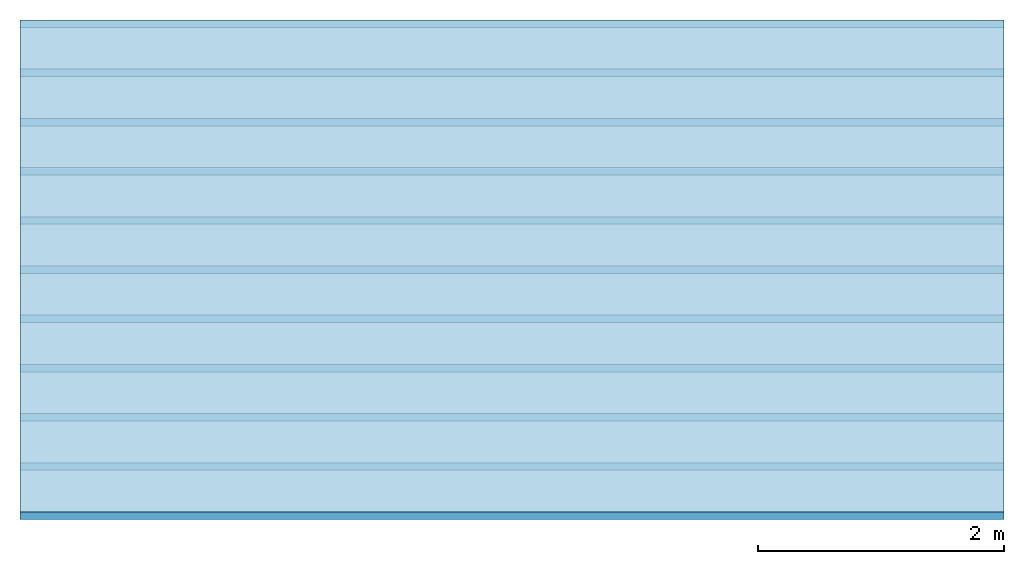
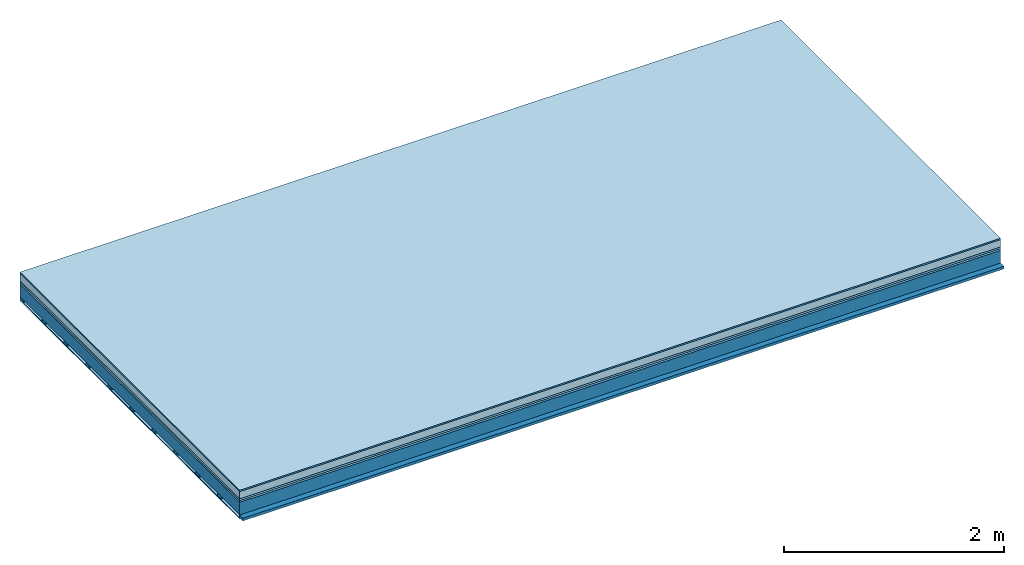
# One storey: 6 plates, 2 members, 1 element without a shape of its own.
"""IFC4 building model written with IfcOpenShell, lengths in metres."""

from ifc_helpers import new_model, si_unit, derived_unit, direction, frame, frame_2d, origin, origin_with_axes, place, context, project, spatial, rectangle, extrude, material, layer, layer_set, type_object, element, aggregate, save


model = new_model("IFC4")

# Units and contexts
plan_context = context("Plan", 3, precision=1e-05, world=origin(), true_north=direction((0.0, 1.0)))
model_context = context("Model", 3, precision=1e-05, world=origin(), true_north=direction((0.0, 1.0)))
ifc_project = project(units=[si_unit("LENGTHUNIT", "METRE"), derived_unit("SOUNDPRESSUREUNIT", [(si_unit("PRESSUREUNIT", "PASCAL", prefix="MICRO"), 0)]), si_unit("ENERGYUNIT", "JOULE", prefix="MEGA"), si_unit("MASSUNIT", "GRAM", prefix="KILO"), derived_unit("THERMALTRANSMITTANCEUNIT", [(si_unit("POWERUNIT", "WATT"), 1), (si_unit("AREAUNIT", "SQUARE_METRE"), -1), (si_unit("THERMODYNAMICTEMPERATUREUNIT", "KELVIN"), -1)]), derived_unit("AREADENSITYUNIT", [(si_unit("MASSUNIT", "GRAM", prefix="KILO"), 1), (si_unit("AREAUNIT", "SQUARE_METRE"), -1)]), derived_unit("USERDEFINED", [(si_unit("ENERGYUNIT", "JOULE", prefix="MEGA"), 1), (si_unit("AREAUNIT", "SQUARE_METRE"), -1)])], contexts=[plan_context, model_context])

# Site, building, storey
site = spatial("IfcSite", under=ifc_project)
building_placement = place(None, origin())
building = spatial("IfcBuilding", under=site, at=building_placement)
storey_placement = place(building_placement, origin())
storey = spatial("IfcBuildingStorey", under=building, at=storey_placement)

# Slab, members, plates
ifc_material_1 = material(Category="11.013")
ifc_layer_1 = layer(ifc_material_1, 0.015, Name="Flooring")
ifc_material_2 = material(Name="Cement screed", Category="04.006")
ifc_layer_2 = layer(ifc_material_2, 0.08, Name="On-material")
ifc_material_3 = material(Name="Wood fiber generic product", Category="10.009")
ifc_layer_3 = layer(ifc_material_3, 0.02, Name="Impact sound insulation")
ifc_material_4 = material(Category="10.004")
ifc_layer_4 = layer(ifc_material_4, 0.02, Name="Additional insulation")
ifc_material_5 = material(Name="no composite action")
ifc_layer_5 = layer(ifc_material_5, 0.0, Name="Bond")
ifc_layer_6 = layer(None, 0.14, Name="Supporting structure")
ifc_material_6 = material(Name="of the art")
ifc_layer_7 = layer(ifc_material_6, 0.0, Name="Bond")
ifc_layer_8 = layer(None, 0.03, Name="Battens / profiles")
ifc_material_7 = material(Name="Plasterboard type A", Category="03.008")
ifc_layer_9 = layer(ifc_material_7, 0.0125, Name="Ceiling covering 1st layer")
ifc_material_8 = material(Category="04.001")
ifc_layer_10 = layer(ifc_material_8, 0.003, Name="Surface / treatment")
ifc_layer_set = layer_set([ifc_layer_1, ifc_layer_2, ifc_layer_3, ifc_layer_4, ifc_layer_5, ifc_layer_6, ifc_layer_7, ifc_layer_8, ifc_layer_9, ifc_layer_10])
slab_type = type_object("IfcSlabType", Name="A2142", PredefinedType="NOTDEFINED", material=ifc_layer_set)
slab_placement = place(None, frame((0.0, 0.0, 0.0), z_axis=(0.0, 0.0, -1.0), x_axis=(1.0, 0.0, 0.0)))
slab = element("IfcSlab", 1, at=slab_placement, inside=storey, type_object=slab_type, material=ifc_layer_set, Name="Slab #1")
ifc_material_9 = material(Name="Solid timber panel")
member_1_placement = place(slab_placement, origin())
member_1 = element("IfcMember", 2, at=member_1_placement, material=ifc_material_9, Name="Supporting structure", context=plan_context, shape_type="SweptSolid", body=[
    extrude(rectangle(XDim=1.0, YDim=0.14, at=frame_2d((0.5, 0.07), x_axis=(1.0, 0.0))), frame((0.0, 4.0, 0.135), z_axis=(0.0, -1.0, 0.0), x_axis=(1.0, 0.0, 0.0)), (0.0, 0.0, 1.0), 4.0),
    extrude(rectangle(XDim=1.0, YDim=0.14, at=frame_2d((0.5, 0.07), x_axis=(1.0, 0.0))), frame((1.0, 4.0, 0.135), z_axis=(0.0, -1.0, 0.0), x_axis=(1.0, 0.0, 0.0)), (0.0, 0.0, 1.0), 4.0),
    extrude(rectangle(XDim=1.0, YDim=0.14, at=frame_2d((0.5, 0.07), x_axis=(1.0, 0.0))), frame((2.0, 4.0, 0.135), z_axis=(0.0, -1.0, 0.0), x_axis=(1.0, 0.0, 0.0)), (0.0, 0.0, 1.0), 4.0),
    extrude(rectangle(XDim=1.0, YDim=0.14, at=frame_2d((0.5, 0.07), x_axis=(1.0, 0.0))), frame((3.0, 4.0, 0.135), z_axis=(0.0, -1.0, 0.0), x_axis=(1.0, 0.0, 0.0)), (0.0, 0.0, 1.0), 4.0),
    extrude(rectangle(XDim=1.0, YDim=0.14, at=frame_2d((0.5, 0.07), x_axis=(1.0, 0.0))), frame((4.0, 4.0, 0.135), z_axis=(0.0, -1.0, 0.0), x_axis=(1.0, 0.0, 0.0)), (0.0, 0.0, 1.0), 4.0),
    extrude(rectangle(XDim=1.0, YDim=0.14, at=frame_2d((0.5, 0.07), x_axis=(1.0, 0.0))), frame((5.0, 4.0, 0.135), z_axis=(0.0, -1.0, 0.0), x_axis=(1.0, 0.0, 0.0)), (0.0, 0.0, 1.0), 4.0),
    extrude(rectangle(XDim=1.0, YDim=0.14, at=frame_2d((0.5, 0.07), x_axis=(1.0, 0.0))), frame((6.0, 4.0, 0.135), z_axis=(0.0, -1.0, 0.0), x_axis=(1.0, 0.0, 0.0)), (0.0, 0.0, 1.0), 4.0),
    extrude(rectangle(XDim=1.0, YDim=0.14, at=frame_2d((0.5, 0.07), x_axis=(1.0, 0.0))), frame((7.0, 4.0, 0.135), z_axis=(0.0, -1.0, 0.0), x_axis=(1.0, 0.0, 0.0)), (0.0, 0.0, 1.0), 4.0),
])
ifc_material_10 = material()
member_2_placement = place(slab_placement, origin())
member_2 = element("IfcMember", 3, at=member_2_placement, material=ifc_material_10, Name="Battens / profiles", context=plan_context, shape_type="SweptSolid", body=[
    extrude(rectangle(XDim=0.06, YDim=0.03, at=frame_2d((0.03, 0.015), x_axis=(1.0, 0.0))), frame((0.0, 0.0, 0.275), z_axis=(1.0, 0.0, 0.0), x_axis=(0.0, 1.0, 0.0)), (0.0, 0.0, 1.0), 8.0),
    extrude(rectangle(XDim=0.06, YDim=0.03, at=frame_2d((0.03, 0.015), x_axis=(1.0, 0.0))), frame((0.0, 0.4, 0.275), z_axis=(1.0, 0.0, 0.0), x_axis=(0.0, 1.0, 0.0)), (0.0, 0.0, 1.0), 8.0),
    extrude(rectangle(XDim=0.06, YDim=0.03, at=frame_2d((0.03, 0.015), x_axis=(1.0, 0.0))), frame((0.0, 0.8, 0.275), z_axis=(1.0, 0.0, 0.0), x_axis=(0.0, 1.0, 0.0)), (0.0, 0.0, 1.0), 8.0),
    extrude(rectangle(XDim=0.06, YDim=0.03, at=frame_2d((0.03, 0.015), x_axis=(1.0, 0.0))), frame((0.0, 1.2, 0.275), z_axis=(1.0, 0.0, 0.0), x_axis=(0.0, 1.0, 0.0)), (0.0, 0.0, 1.0), 8.0),
    extrude(rectangle(XDim=0.06, YDim=0.03, at=frame_2d((0.03, 0.015), x_axis=(1.0, 0.0))), frame((0.0, 1.6, 0.275), z_axis=(1.0, 0.0, 0.0), x_axis=(0.0, 1.0, 0.0)), (0.0, 0.0, 1.0), 8.0),
    extrude(rectangle(XDim=0.06, YDim=0.03, at=frame_2d((0.03, 0.015), x_axis=(1.0, 0.0))), frame((0.0, 2.0, 0.275), z_axis=(1.0, 0.0, 0.0), x_axis=(0.0, 1.0, 0.0)), (0.0, 0.0, 1.0), 8.0),
    extrude(rectangle(XDim=0.06, YDim=0.03, at=frame_2d((0.03, 0.015), x_axis=(1.0, 0.0))), frame((0.0, 2.4, 0.275), z_axis=(1.0, 0.0, 0.0), x_axis=(0.0, 1.0, 0.0)), (0.0, 0.0, 1.0), 8.0),
    extrude(rectangle(XDim=0.06, YDim=0.03, at=frame_2d((0.03, 0.015), x_axis=(1.0, 0.0))), frame((0.0, 2.8, 0.275), z_axis=(1.0, 0.0, 0.0), x_axis=(0.0, 1.0, 0.0)), (0.0, 0.0, 1.0), 8.0),
    extrude(rectangle(XDim=0.06, YDim=0.03, at=frame_2d((0.03, 0.015), x_axis=(1.0, 0.0))), frame((0.0, 3.2, 0.275), z_axis=(1.0, 0.0, 0.0), x_axis=(0.0, 1.0, 0.0)), (0.0, 0.0, 1.0), 8.0),
    extrude(rectangle(XDim=0.06, YDim=0.03, at=frame_2d((0.03, 0.015), x_axis=(1.0, 0.0))), frame((0.0, 3.6, 0.275), z_axis=(1.0, 0.0, 0.0), x_axis=(0.0, 1.0, 0.0)), (0.0, 0.0, 1.0), 8.0),
    extrude(rectangle(XDim=0.06, YDim=0.03, at=frame_2d((0.03, 0.015), x_axis=(1.0, 0.0))), frame((0.0, 4.0, 0.275), z_axis=(1.0, 0.0, 0.0), x_axis=(0.0, 1.0, 0.0)), (0.0, 0.0, 1.0), 8.0),
])
plate_1_placement = place(slab_placement, origin())
plate_1 = element("IfcPlate", 4, at=plate_1_placement, material=ifc_material_1, Name="Flooring", context=plan_context, shape_type="SweptSolid", body=[
    extrude(rectangle(XDim=8.0, YDim=4.0, at=frame_2d((4.0, 2.0), x_axis=(1.0, 0.0))), origin_with_axes(), (0.0, 0.0, 1.0), 0.015),
])
plate_2_placement = place(slab_placement, origin())
plate_2 = element("IfcPlate", 5, at=plate_2_placement, material=ifc_material_2, Name="On-material", context=plan_context, shape_type="SweptSolid", body=[
    extrude(rectangle(XDim=8.0, YDim=4.0, at=frame_2d((4.0, 2.0), x_axis=(1.0, 0.0))), frame((0.0, 0.0, 0.015), z_axis=(0.0, 0.0, 1.0), x_axis=(1.0, 0.0, 0.0)), (0.0, 0.0, 1.0), 0.08),
])
plate_3_placement = place(slab_placement, origin())
plate_3 = element("IfcPlate", 6, at=plate_3_placement, material=ifc_material_3, Name="Impact sound insulation", context=plan_context, shape_type="SweptSolid", body=[
    extrude(rectangle(XDim=8.0, YDim=4.0, at=frame_2d((4.0, 2.0), x_axis=(1.0, 0.0))), frame((0.0, 0.0, 0.095), z_axis=(0.0, 0.0, 1.0), x_axis=(1.0, 0.0, 0.0)), (0.0, 0.0, 1.0), 0.02),
])
plate_4_placement = place(slab_placement, origin())
plate_4 = element("IfcPlate", 7, at=plate_4_placement, material=ifc_material_4, Name="Additional insulation", context=plan_context, shape_type="SweptSolid", body=[
    extrude(rectangle(XDim=8.0, YDim=4.0, at=frame_2d((4.0, 2.0), x_axis=(1.0, 0.0))), frame((0.0, 0.0, 0.115), z_axis=(0.0, 0.0, 1.0), x_axis=(1.0, 0.0, 0.0)), (0.0, 0.0, 1.0), 0.02),
])
plate_5_placement = place(slab_placement, origin())
plate_5 = element("IfcPlate", 8, at=plate_5_placement, material=ifc_material_7, Name="Ceiling covering 1st layer", context=plan_context, shape_type="SweptSolid", body=[
    extrude(rectangle(XDim=8.0, YDim=4.0, at=frame_2d((4.0, 2.0), x_axis=(1.0, 0.0))), frame((0.0, 0.0, 0.305), z_axis=(0.0, 0.0, 1.0), x_axis=(1.0, 0.0, 0.0)), (0.0, 0.0, 1.0), 0.0125),
])
plate_6_placement = place(slab_placement, origin())
plate_6 = element("IfcPlate", 9, at=plate_6_placement, material=ifc_material_8, Name="Surface / treatment", context=plan_context, shape_type="SweptSolid", body=[
    extrude(rectangle(XDim=8.0, YDim=4.0, at=frame_2d((4.0, 2.0), x_axis=(1.0, 0.0))), frame((0.0, 0.0, 0.3175), z_axis=(0.0, 0.0, 1.0), x_axis=(1.0, 0.0, 0.0)), (0.0, 0.0, 1.0), 0.003),
])
aggregate(slab, [plate_1, plate_2, plate_3, plate_4, member_1, member_2, plate_5, plate_6])

save(model, "model.ifc")
